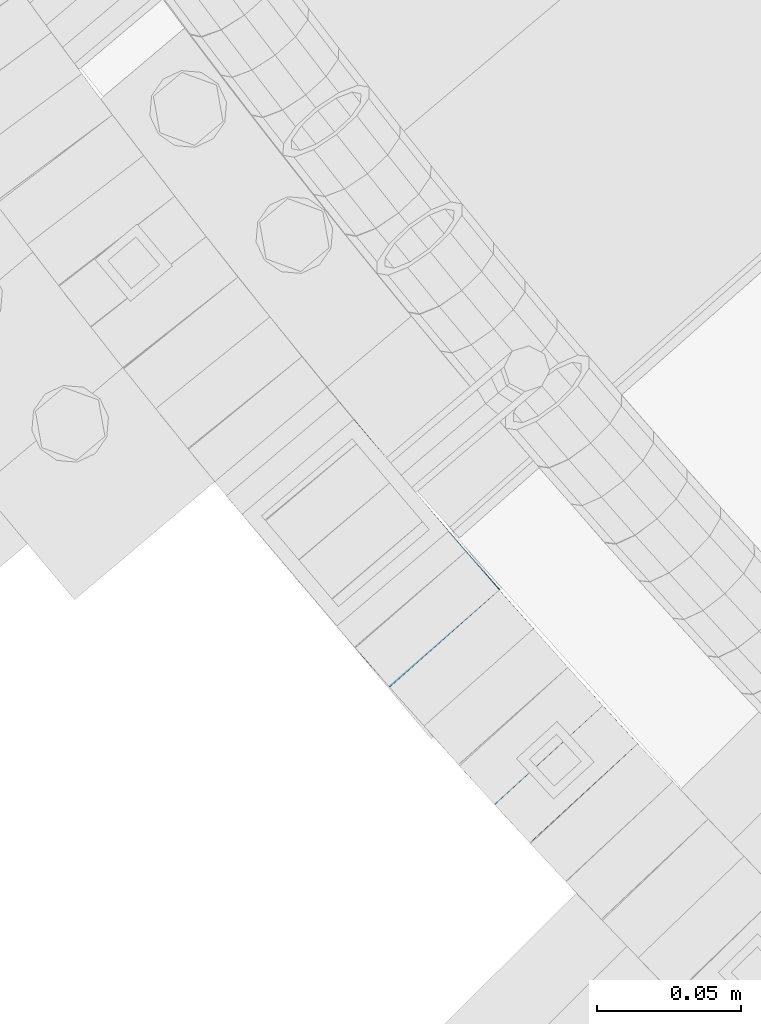
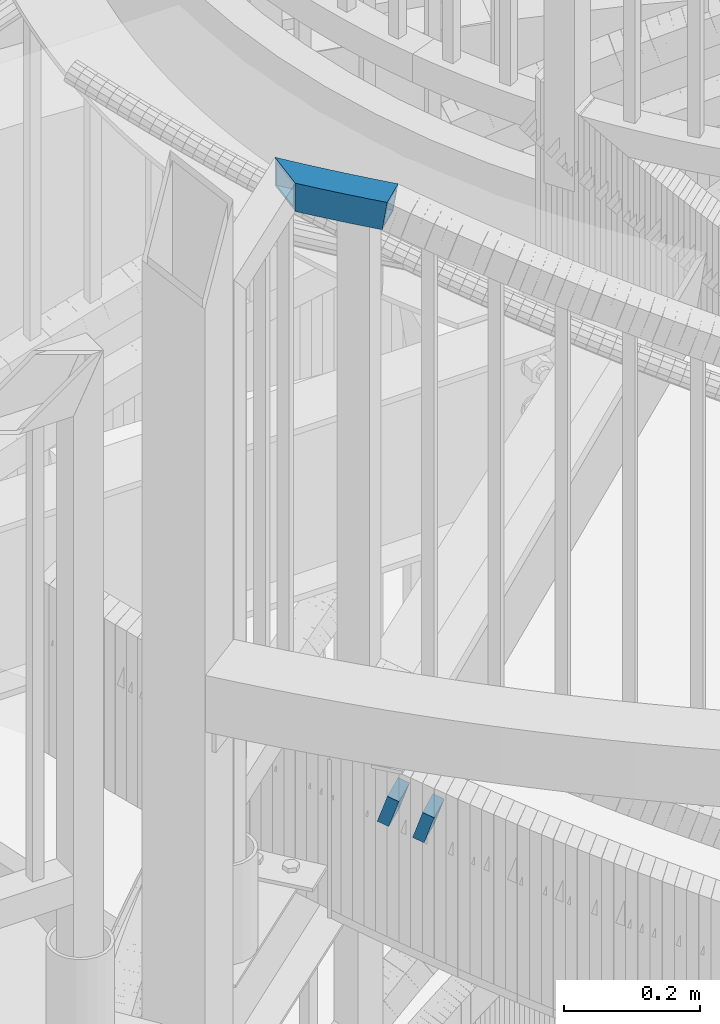
# One storey, part 464 of 975: 3 beams.
"""IFC2X3 building model written with IfcOpenShell, lengths in millimetres."""

import ifcopenshell
import ifcopenshell.guid

model = None  # the IFC model being written
_history = None  # IfcOwnerHistory: only IFC2X3 demands one
_inside = {}  # id of a spatial element -> (the spatial element, [elements in it])
_under = {}  # id of a project, library or spatial element -> (it, [spatial elements below it])
_declared = {}  # id of a project -> (the project, [libraries it declares])
_typed = {}  # id of a type object -> (the type object, [elements of that type])
_made_of = {}  # id of a material, layer set ... -> (it, [elements and type objects made of it])


def new_model(schema):
    """Start an empty IFC model of exactly this schema.

    Asked for "IFC4X3", IfcOpenShell would pick the latest addendum, in which some entities
    have other attributes; the version numbers below select the first issue.
    IFC2X3 requires an IfcOwnerHistory on every rooted entity: one is made here for all.
    """
    global model, _history
    if schema == "IFC4X3":
        model = ifcopenshell.file(schema_version=(4, 3, 0, 0))
    else:
        model = ifcopenshell.file(schema=schema)
    _inside.clear()
    _under.clear()
    _declared.clear()
    _typed.clear()
    _made_of.clear()
    _history = None
    if model.schema == "IFC2X3":
        org = make("IfcOrganization", Name="unknown")
        user = make(
            "IfcPersonAndOrganization",
            ThePerson=make("IfcPerson", FamilyName="unknown"),
            TheOrganization=org,
        )
        app = make(
            "IfcApplication",
            ApplicationDeveloper=org,
            Version="unknown",
            ApplicationFullName="unknown",
            ApplicationIdentifier="unknown",
        )
        _history = make(
            "IfcOwnerHistory",
            OwningUser=user,
            OwningApplication=app,
            ChangeAction="ADDED",
            CreationDate=0,
        )
    return model


def make(cls, **values):
    """One entity of the class cls with the attributes given. An attribute that is None is left unset."""
    return model.create_entity(
        cls, **{name: value for name, value in values.items() if value is not None}
    )


def rooted(cls, **values):
    """An entity with a GlobalId (a new one), such as an element, a storey or a relation."""
    return make(cls, GlobalId=ifcopenshell.guid.new(), OwnerHistory=_history, **values)


def si_unit(unit_type, name, prefix=None):
    """IfcSIUnit, for example si_unit("LENGTHUNIT", "METRE", prefix="MILLI")."""
    return make("IfcSIUnit", UnitType=unit_type, Prefix=prefix, Name=name)


def assignment(units):
    """IfcUnitAssignment: the units of a project."""
    return None if units is None else make("IfcUnitAssignment", Units=units)


def point(xyz):
    """IfcCartesianPoint."""
    return None if xyz is None else make("IfcCartesianPoint", Coordinates=xyz)


def direction(xyz):
    """IfcDirection."""
    return None if xyz is None else make("IfcDirection", DirectionRatios=xyz)


def frame(location, z_axis=None, x_axis=None):
    """IfcAxis2Placement3D, a coordinate frame: its origin and axes. An axis left out is left unset."""
    return make(
        "IfcAxis2Placement3D",
        Location=point(location),
        Axis=direction(z_axis),
        RefDirection=direction(x_axis),
    )


def origin_with_axes():
    """The frame at (0, 0, 0) with the z axis (0, 0, 1) and the x axis (1, 0, 0) written out."""
    return frame((0.0, 0.0, 0.0), z_axis=(0.0, 0.0, 1.0), x_axis=(1.0, 0.0, 0.0))


def place(relative_to, where):
    """IfcLocalPlacement: puts the frame where relative to a parent placement (None: the world)."""
    return make(
        "IfcLocalPlacement", PlacementRelTo=relative_to, RelativePlacement=where
    )


def context(
    kind, dimensions, precision=None, world=None, true_north=None, identifier=None
):
    """IfcGeometricRepresentationContext, for example the 3D "Model" context."""
    return make(
        "IfcGeometricRepresentationContext",
        ContextIdentifier=identifier,
        ContextType=kind,
        CoordinateSpaceDimension=dimensions,
        Precision=precision,
        WorldCoordinateSystem=world,
        TrueNorth=true_north,
    )


def subcontext(parent, identifier, kind, view, scale=None):
    """IfcGeometricRepresentationSubContext, for example "Body" below "Model"."""
    return make(
        "IfcGeometricRepresentationSubContext",
        ContextIdentifier=identifier,
        ContextType=kind,
        ParentContext=parent,
        TargetScale=scale,
        TargetView=view,
    )


def project(units=None, contexts=None):
    """IfcProject with its units and contexts."""
    return rooted(
        "IfcProject",
        Name="project",
        RepresentationContexts=contexts,
        UnitsInContext=assignment(units),
    )


def spatial(cls, under=None, at=None, **own):
    """A site, building, storey or space (cls), placed at a placement, below another one or the project."""
    s = rooted(cls, ObjectPlacement=at, **own)
    if under is not None:
        _under.setdefault(under.id(), (under, []))[1].append(s)
    return s


def faces_of(points, faces, orient=None, outer=None):
    """IfcFace entities. A face is a list of loops; a loop is a list of indices into points, from 0.

    orient and outer hold one flag for each loop. By default every Orientation is true, the
    first loop of a face is its IfcFaceOuterBound and the others are IfcFaceBound.
    """
    made = []
    for i, loops in enumerate(faces):
        bounds = []
        for j, loop in enumerate(loops):
            is_outer = j == 0 if outer is None else outer[i][j]
            bounds.append(
                make(
                    "IfcFaceOuterBound" if is_outer else "IfcFaceBound",
                    Bound=make("IfcPolyLoop", Polygon=[points[k] for k in loop]),
                    Orientation=True if orient is None else orient[i][j],
                )
            )
        made.append(make("IfcFace", Bounds=bounds))
    return made


def faceted_brep(points, faces, orient=None, outer=None, voids=None):
    """IfcFacetedBrep: a solid bounded by flat faces; with voids (closed shells), ...WithVoids."""
    shared = [point(p) for p in points]
    hull = make("IfcClosedShell", CfsFaces=faces_of(shared, faces, orient, outer))
    if voids is None:
        return make("IfcFacetedBrep", Outer=hull)
    return make(
        "IfcFacetedBrepWithVoids",
        Outer=hull,
        Voids=[
            make(cls, CfsFaces=faces_of(shared, fs, o, b)) for cls, fs, o, b in voids
        ],
    )


def shape(context_of_items, identifier, shape_type, items):
    """IfcShapeRepresentation: the items that make up one representation, for example the "Body"."""
    return make(
        "IfcShapeRepresentation",
        ContextOfItems=context_of_items,
        RepresentationIdentifier=identifier,
        RepresentationType=shape_type,
        Items=items,
    )


def material(Name=None, Category=None):
    """IfcMaterial."""
    return make("IfcMaterial", Name=Name, Category=Category)


def made_of(thing, what):
    """Note that an element or type object is made of a material, layer set ...; save() writes the relation."""
    if what is not None:
        _made_of.setdefault(what.id(), (what, []))[1].append(thing)
    return thing


def type_object(cls, material=None, **own):
    """A type object (cls), such as IfcWallType, which elements share."""
    return made_of(rooted(cls, **own), material)


def element(
    cls,
    number,
    at=None,
    inside=None,
    cuts=None,
    type_object=None,
    material=None,
    context=None,
    identifier="Body",
    shape_type=None,
    held_by="IfcProductDefinitionShape",
    body=None,
    shapes=None,
    **own,
):
    """One element of the class cls, such as IfcWall. Its Tag is "e" and its number.

    at: its placement. inside: the storey or other place that contains it. cuts: it is an
    opening in that element (IfcRelVoidsElement). A single representation is given by context,
    identifier, shape_type and body (its items); several are given by shapes. held_by: the class
    of the entity that holds the representations. save() writes the other relations.
    """
    e = rooted(cls, Tag="e%d" % number, ObjectPlacement=at, **own)
    if body is not None:
        shapes = [shape(context, identifier, shape_type, body)]
    if shapes is not None:
        e.Representation = make(held_by, Representations=shapes)
    if inside is not None:
        _inside.setdefault(inside.id(), (inside, []))[1].append(e)
    if cuts is not None:
        rooted(
            "IfcRelVoidsElement", RelatingBuildingElement=cuts, RelatedOpeningElement=e
        )
    if type_object is not None:
        _typed.setdefault(type_object.id(), (type_object, []))[1].append(e)
    return made_of(e, material)


def aggregate(whole, parts):
    """IfcRelAggregates: a whole, such as a stair, and the parts it consists of."""
    return rooted("IfcRelAggregates", RelatingObject=whole, RelatedObjects=parts)


def save(model, path):
    """Write the relations noted so far, then the file.

    IfcRelAggregates (storeys below a building ...), IfcRelContainedInSpatialStructure (elements
    in a storey), IfcRelDefinesByType, IfcRelAssociatesMaterial and IfcRelDeclares: one each for
    every whole, place, type object, material and project.
    """
    for whole, parts in _under.values():
        aggregate(whole, parts)
    for where, things in _inside.values():
        rooted(
            "IfcRelContainedInSpatialStructure",
            RelatedElements=things,
            RelatingStructure=where,
        )
    for kind, things in _typed.values():
        rooted("IfcRelDefinesByType", RelatedObjects=things, RelatingType=kind)
    for what, things in _made_of.values():
        rooted("IfcRelAssociatesMaterial", RelatedObjects=things, RelatingMaterial=what)
    for by, libraries in _declared.values():
        rooted("IfcRelDeclares", RelatingContext=by, RelatedDefinitions=libraries)
    model.write(path)


model = new_model("IFC2X3")

# Units and contexts
model_context = context("Model", 3, precision=1e-05, world=origin_with_axes())
body_context = subcontext(model_context, "Body", "Model", "MODEL_VIEW")
ifc_project = project(units=[si_unit("LENGTHUNIT", "METRE", prefix="MILLI"), si_unit("AREAUNIT", "SQUARE_METRE"), si_unit("VOLUMEUNIT", "CUBIC_METRE"), si_unit("MASSUNIT", "GRAM", prefix="KILO"), si_unit("TIMEUNIT", "SECOND"), si_unit("PLANEANGLEUNIT", "RADIAN"), si_unit("SOLIDANGLEUNIT", "STERADIAN"), si_unit("THERMODYNAMICTEMPERATUREUNIT", "DEGREE_CELSIUS"), si_unit("LUMINOUSINTENSITYUNIT", "LUMEN")], contexts=[model_context])

# Site, building, storey
site_placement = place(None, origin_with_axes())
site = spatial("IfcSite", under=ifc_project, at=site_placement, CompositionType="ELEMENT")
building_placement = place(site_placement, origin_with_axes())
building = spatial("IfcBuilding", under=site, at=building_placement, Name="Undefined", CompositionType="ELEMENT")
storey_placement = place(building_placement, origin_with_axes())
storey = spatial("IfcBuildingStorey", under=building, at=storey_placement, Name="Undefined", CompositionType="ELEMENT", Elevation=0.0)

# Beams
ifc_material = material()
beam_type = type_object("IfcBeamType", Name="HSS2X2X.188_TUBES", PredefinedType="NOTDEFINED")
beam_1_placement = place(storey_placement, frame((32612.3422775604, 1471.11594026846, 5130.8), z_axis=(0.0, 0.0, 1.0), x_axis=(-0.644936637664488, 0.76423604560242, 0.0)))
element("IfcBeam", 1, at=beam_1_placement, inside=storey, type_object=beam_type, material=ifc_material, Name="HANDRAIL", ObjectType="HSS2X2X.188_TUBES", context=body_context, shape_type="Brep", body=[
    faceted_brep([(55.4866860684269, -23.8479305757173, 25.3999999999996), (51.8505932737062, -23.9176642509301, 25.3999999999996), (51.8505932737062, -23.9176642509301, 0.0465926285069145), (55.4866860684269, -23.8479305757173, -23.6106126499226), (48.2145925969344, -23.9920462097361, 25.3999999999996), (48.2145925969344, -23.9920462097361, 23.703839084139), (47.9539081902258, -23.9977124561519, 25.3999999999996), (47.1431262087099, 26.7966529247497, 25.3999999999996), (47.1431262087099, 26.7966529247497, 23.6763622849121), (46.8782188694749, 26.7908948885088, 25.3999999999996), (50.8440554689951, 26.8723631328212, 25.3999999999996), (50.8440554689951, 26.8723631328212, -0.403335000283732), (184.092952909432, 26.4465017965631, -25.3999999999996), (184.092952909432, 26.4465017965631, 25.3999999999996), (187.793322633312, 26.3471371558007, 25.3999999999996), (187.793322633312, 26.3471371558007, -25.3999999999996), (180.392459182614, 26.5411358446399, -25.3999999999996), (180.392459182614, 26.5411358446399, 25.3999999999996), (176.691847500504, 26.6310391453771, -25.3999999999996), (176.691847500504, 26.6310391453771, 25.3999999999996), (172.991123910928, 26.7162115518404, -25.3999999999996), (172.991123910928, 26.7162115518404, 25.3999999999996), (169.290294461902, 26.7966529248406, -25.3999999999996), (169.290294461902, 26.7966529248406, 25.3999999999996), (165.589365201617, 26.8723631329085, -25.3999999999996), (165.589365201617, 26.8723631329085, 25.3999999999996), (161.888342178416, 26.9433420523128, -25.3999999999996), (161.888342178416, 26.9433420523128, 25.3999999999996), (158.187231440806, 27.0095895670602, -25.3999999999996), (158.187231440806, 27.0095895670602, 25.3999999999996), (154.486039037434, 27.0711055688807, -25.3999999999996), (154.486039037434, 27.0711055688807, 25.3999999999996), (150.784771017079, 27.1278899572353, -25.3999999999996), (150.784771017079, 27.1278899572353, 25.3999999999996), (147.083433428645, 27.1799426393336, -25.3999999999996), (147.083433428645, 27.1799426393336, 25.3999999999996), (143.382032321151, 27.2272635300942, -25.3999999999996), (143.382032321151, 27.2272635300942, 25.3999999999996), (139.680573743721, 27.2698525521919, -25.3999999999996), (139.680573743721, 27.2698525521919, 25.3999999999996), (135.979063745563, 27.3077096360139, -25.3999999999996), (135.979063745563, 27.3077096360139, 25.3999999999996), (132.277508375977, 27.3408347197001, -25.3999999999996), (132.277508375977, 27.3408347197001, 25.3999999999996), (128.575913684344, 27.3692277491136, -25.3999999999996), (128.575913684344, 27.3692277491136, 25.3999999999996), (124.874285720092, 27.3928886778449, -25.3999999999996), (124.874285720092, 27.3928886778449, 25.3999999999996), (121.172630532721, 27.4118174672403, -25.3999999999996), (121.172630532721, 27.4118174672403, 25.3999999999996), (117.470954171764, 27.4260140863444, -25.3999999999996), (117.470954171764, 27.4260140863444, 25.3999999999996), (113.769262686794, 27.4354785119758, -25.3999999999996), (113.769262686794, 27.4354785119758, 25.3999999999996), (110.067562127402, 27.4402107286551, -25.3999999999996), (110.067562127402, 27.4402107286551, 25.3999999999996), (106.365858543206, 27.4402107286514, -25.3999999999996), (106.365858543206, 27.4402107286514, 25.3999999999996), (102.664157983814, 27.4354785119649, -25.3999999999996), (102.664157983814, 27.4354785119649, 25.3999999999996), (98.9624664988478, 27.4260140863335, -25.3999999999996), (98.9624664988478, 27.4260140863335, 25.3999999999996), (95.2607901378906, 27.4118174672185, -25.3999999999996), (95.2607901378906, 27.4118174672185, 25.3999999999996), (91.5591349505194, 27.3928886778231, -25.3999999999996), (91.5591349505194, 27.3928886778231, 25.3999999999996), (87.8575069862709, 27.3692277490809, -25.3999999999996), (87.8575069862709, 27.3692277490809, 25.3999999999996), (84.1559122946346, 27.3408347196637, -25.3999999999996), (84.1559122946346, 27.3408347196637, 25.3999999999996), (80.4543569250491, 27.3077096359739, -25.3999999999996), (80.4543569250491, 27.3077096359739, 25.3999999999996), (76.7528469268946, 27.2698525521446, -25.3999999999996), (76.7528469268946, 27.2698525521446, 25.3999999999996), (73.0513883494568, 27.2272635300433, -25.3999999999996), (73.0513883494568, 27.2272635300433, 25.3999999999996), (69.3499872419634, 27.1799426392754, -25.3999999999996), (69.3499872419634, 27.1799426392754, 25.3999999999996), (65.6486496535326, 27.1278899571771, -25.3999999999996), (65.6486496535326, 27.1278899571771, 25.3999999999996), (61.9473816331774, 27.0711055688153, -25.3999999999996), (61.9473816331774, 27.0711055688153, 25.3999999999996), (58.2461892298052, 27.0095895669911, -25.3999999999996), (58.2461892298052, 27.0095895669911, 25.3999999999996), (54.5450784921959, 26.9433420522364, -25.3999999999996), (54.5450784921959, 26.9433420522364, 25.3999999999996), (233.854294109802, -21.3677338411799, -20.6374999999998), (233.854294109802, -21.3677338411799, 20.6374999999998), (237.493497984808, -21.5306737560713, 20.6374999999998), (237.493497984808, -21.5306737560713, -20.6374999999998), (230.214884907968, -21.2094463771828, -20.6374999999998), (230.214884907968, -21.2094463771828, 20.6374999999998), (226.575276327105, -21.0558116227694, -20.6374999999998), (226.575276327105, -21.0558116227694, 20.6374999999998), (222.935474315345, -20.9068298290149, -20.6374999999998), (222.935474315345, -20.9068298290149, 20.6374999999998), (219.295484821145, -20.7625012394019, -20.6374999999998), (219.295484821145, -20.7625012394019, 20.6374999999998), (215.655313793257, -20.6228260897988, -20.6374999999998), (215.655313793257, -20.6228260897988, 20.6374999999998), (212.014967180745, -20.4878046084814, -20.6374999999998), (212.014967180745, -20.4878046084814, 20.6374999999998), (208.374450932941, -20.3574370161041, -20.6374999999998), (208.374450932941, -20.3574370161041, 20.6374999999998), (204.733770999461, -20.2317235257287, -20.6374999999998), (204.733770999461, -20.2317235257287, 20.6374999999998), (201.092933330205, -20.1106643428066, -20.6374999999998), (201.092933330205, -20.1106643428066, 20.6374999999998), (197.451943875305, -19.9942596651781, -20.6374999999998), (197.451943875305, -19.9942596651781, 20.6374999999998), (193.810808585153, -19.8825096830842, -20.6374999999998), (193.810808585153, -19.8825096830842, 20.6374999999998), (190.169533410386, -19.775414579155, -20.6374999999998), (190.169533410386, -19.775414579155, 20.6374999999998), (186.528124301854, -19.6729745284174, -20.6374999999998), (186.528124301854, -19.6729745284174, 20.6374999999998), (182.886587210643, -19.5751896982802, -20.6374999999998), (182.886587210643, -19.5751896982802, 20.6374999999998), (179.244928088039, -19.4820602485524, -20.6374999999998), (179.244928088039, -19.4820602485524, 20.6374999999998), (175.60315288552, -19.3935863314364, -20.6374999999998), (175.60315288552, -19.3935863314364, 20.6374999999998), (171.961267554772, -19.3097680915198, -20.6374999999998), (171.961267554772, -19.3097680915198, 20.6374999999998), (168.319278047649, -19.2306056657908, -20.6374999999998), (168.319278047649, -19.2306056657908, 20.6374999999998), (164.677190316168, -19.1560991836195, -20.6374999999998), (164.677190316168, -19.1560991836195, 20.6374999999998), (161.035010312524, -19.0862487667655, -20.6374999999998), (161.035010312524, -19.0862487667655, 20.6374999999998), (157.392743989058, -19.0210545293921, -20.6374999999998), (157.392743989058, -19.0210545293921, 20.6374999999998), (153.750397298238, -18.9605165780449, -20.6374999999998), (153.750397298238, -18.9605165780449, 20.6374999999998), (150.107976192678, -18.9046350116514, -20.6374999999998), (150.107976192678, -18.9046350116514, 20.6374999999998), (146.465486625115, -18.8534099215394, -20.6374999999998), (146.465486625115, -18.8534099215394, 20.6374999999998), (142.822934548385, -18.8068413914334, -20.6374999999998), (142.822934548385, -18.8068413914334, 20.6374999999998), (139.18032591544, -18.764929497429, -20.6374999999998), (139.18032591544, -18.764929497429, 20.6374999999998), (135.537666679313, -18.7276743080256, -20.6374999999998), (135.537666679313, -18.7276743080256, 20.6374999999998), (131.894962793129, -18.6950758841158, -20.6374999999998), (131.894962793129, -18.6950758841158, 20.6374999999998), (128.252220210077, -18.6671342789668, -20.6374999999998), (128.252220210077, -18.6671342789668, 20.6374999999998), (124.609444883419, -18.6438495382426, -20.6374999999998), (124.609444883419, -18.6438495382426, 20.6374999999998), (120.96664276646, -18.6252217000001, -20.6374999999998), (120.96664276646, -18.6252217000001, 20.6374999999998), (117.323819812558, -18.6112507946818, -20.6374999999998), (117.323819812558, -18.6112507946818, 20.6374999999998), (113.680981975103, -18.6019368451161, -20.6374999999998), (113.680981975103, -18.6019368451161, 20.6374999999998), (110.038135207498, -18.5972798665316, -20.6374999999998), (110.038135207498, -18.5972798665316, 20.6374999999998), (106.395285463183, -18.5972798665352, -20.6374999999998), (106.395285463183, -18.5972798665352, 20.6374999999998), (102.752438695577, -18.6019368451271, -20.6374999999998), (102.752438695577, -18.6019368451271, 20.6374999999998), (99.1096008581226, -18.6112507946964, -20.6374999999998), (99.1096008581226, -18.6112507946964, 20.6374999999998), (95.4667779042175, -18.6252217000183, -20.6374999999998), (95.4667779042175, -18.6252217000183, 20.6374999999998), (91.8239757872652, -18.6438495382645, -20.6374999999998), (91.8239757872652, -18.6438495382645, 20.6374999999998), (88.1812004606036, -18.6671342789996, -20.6374999999998), (88.1812004606036, -18.6671342789996, 20.6374999999998), (84.538457877552, -18.6950758841485, -20.6374999999998), (84.538457877552, -18.6950758841485, 20.6374999999998), (80.8957539913681, -18.7276743080693, -20.6374999999998), (80.8957539913681, -18.7276743080693, 20.6374999999998), (77.2530947552405, -18.7649294974726, -20.6374999999998), (77.2530947552405, -18.7649294974726, 20.6374999999998), (73.6104861222957, -18.8068413914807, -20.6374999999998), (73.6104861222957, -18.8068413914807, 20.6374999999998), (69.9679340455659, -18.8534099215976, -20.6374999999998), (69.9679340455659, -18.8534099215976, 20.6374999999998), (66.3254444780032, -18.9046350117096, -20.6374999999998), (66.3254444780032, -18.9046350117096, 20.6374999999998), (62.6830233724468, -18.9605165781068, -20.6374999999998), (62.6830233724468, -18.9605165781068, 20.6374999999998), (59.0406766816268, -19.0210545294649, -20.6374999999998), (59.0406766816268, -19.0210545294649, 20.6374999999998), (55.398410358157, -19.0862487668492, -20.6374999999998), (55.398410358157, -19.0862487668492, 20.6374999999998), (51.7562303545164, -19.1560991837032, 20.6374999999998), (54.9288750643973, -19.0952536035002, -20.6374999999998), (51.7562303545164, -19.1560991837032, 0.00441191330810398), (48.5850277216196, -19.2209727314766, 20.6374999999998), (50.9384183881848, 22.1107980655943, 20.6374999999998), (47.7110300556051, 22.0447751224347, 20.6374999999998), (50.9384183881848, 22.1107980655943, -0.361154285084922), (54.6333542024695, 22.1816602433646, -20.6374999999998), (54.6333542024695, 22.1816602433646, 20.6374999999998), (54.0548758771256, 22.1705660766493, -20.6374999999998), (58.3283775868877, 22.2477987983875, -20.6374999999998), (58.3283775868877, 22.2477987983875, 20.6374999999998), (62.0234825027546, 22.3092136225787, -20.6374999999998), (62.0234825027546, 22.3092136225787, 20.6374999999998), (65.7186629112366, 22.3659046155663, -20.6374999999998), (65.7186629112366, 22.3659046155663, 20.6374999999998), (69.4139127733724, 22.4178716847018, -20.6374999999998), (69.4139127733724, 22.4178716847018, 20.6374999999998), (73.1092260500955, 22.4651147450604, -20.6374999999998), (73.1092260500955, 22.4651147450604, 20.6374999999998), (76.8045967022372, 22.5076337194223, -20.6374999999998), (76.8045967022372, 22.5076337194223, 20.6374999999998), (80.5000186905309, 22.545428538313, -20.6374999999998), (80.5000186905309, 22.545428538313, 20.6374999999998), (84.1954859756261, 22.5784991399596, -20.6374999999998), (84.1954859756261, 22.5784991399596, 20.6374999999998), (87.890992518096, 22.6068454703163, -20.6374999999998), (87.890992518096, 22.6068454703163, 20.6374999999998), (91.5865322784557, 22.6304674830535, -20.6374999999998), (91.5865322784557, 22.6304674830535, 20.6374999999998), (95.2820992171655, 22.6493651395758, -20.6374999999998), (95.2820992171655, 22.6493651395758, 20.6374999999998), (98.9776872946313, 22.6635384089859, -20.6374999999998), (98.9776872946313, 22.6635384089859, 20.6374999999998), (102.673290471241, 22.6729872681317, -20.6374999999998), (102.673290471241, 22.6729872681317, 20.6374999999998), (106.368902707341, 22.6777117015663, -20.6374999999998), (106.368902707341, 22.6777117015663, 20.6374999999998), (110.064517963274, 22.6777117015663, -20.6374999999998), (110.064517963274, 22.6777117015663, 20.6374999999998), (113.760130199378, 22.672987268139, -20.6374999999998), (113.760130199378, 22.672987268139, 20.6374999999998), (117.455733375988, 22.6635384090005, -20.6374999999998), (117.455733375988, 22.6635384090005, 20.6374999999998), (121.151321453453, 22.6493651395904, -20.6374999999998), (121.151321453453, 22.6493651395904, 20.6374999999998), (124.846888392163, 22.630467483079, -20.6374999999998), (124.846888392163, 22.630467483079, 20.6374999999998), (128.542428152523, 22.6068454703454, -20.6374999999998), (128.542428152523, 22.6068454703454, 20.6374999999998), (132.237934694993, 22.5784991399996, -20.6374999999998), (132.237934694993, 22.5784991399996, 20.6374999999998), (135.933401980088, 22.545428538353, -20.6374999999998), (135.933401980088, 22.545428538353, 20.6374999999998), (139.628823968378, 22.5076337194732, -20.6374999999998), (139.628823968378, 22.5076337194732, 20.6374999999998), (143.324194620523, 22.4651147451114, -20.6374999999998), (143.324194620523, 22.4651147451114, 20.6374999999998), (147.01950789725, 22.41787168476, -20.6374999999998), (147.01950789725, 22.41787168476, 20.6374999999998), (150.714757759382, 22.3659046156281, -20.6374999999998), (150.714757759382, 22.3659046156281, 20.6374999999998), (154.409938167861, 22.3092136226478, -20.6374999999998), (154.409938167861, 22.3092136226478, 20.6374999999998), (158.105043083731, 22.2477987984603, -20.6374999999998), (158.105043083731, 22.2477987984603, 20.6374999999998), (161.800066468149, 22.1816602434446, -20.6374999999998), (161.800066468149, 22.1816602434446, 20.6374999999998), (165.495002282434, 22.110798065678, -20.6374999999998), (165.495002282434, 22.110798065678, 20.6374999999998), (169.189844488013, 22.0352123809826, -20.6374999999998), (169.189844488013, 22.0352123809826, 20.6374999999998), (172.884587046497, 21.9549033128751, -20.6374999999998), (172.884587046497, 21.9549033128751, 20.6374999999998), (176.579223919645, 21.869870992603, -20.6374999999998), (176.579223919645, 21.869870992603, 20.6374999999998), (180.273749069383, 21.7801155591369, -20.6374999999998), (180.273749069383, 21.7801155591369, 20.6374999999998), (183.968156457831, 21.6856371591675, -20.6374999999998), (183.968156457831, 21.6856371591675, 20.6374999999998), (187.662440047297, 21.586435947087, -20.6374999999998), (187.662440047297, 21.586435947087, 20.6374999999998), (191.356593800301, 21.4825120850292, -20.6374999999998), (191.356593800301, 21.4825120850292, 20.6374999999998), (195.050611679551, 21.3738657428257, -20.6374999999998), (195.050611679551, 21.3738657428257, 20.6374999999998), (195.799323266823, 21.3508870562873, -20.6374999999998), (195.799323266823, 21.3508870562873, 20.6374999999998), (55.761720863713, -23.8430076288096, -25.3999999999996), (59.1228650387129, -23.7828452980684, -25.3999999999996), (59.1228650387129, -23.7828452980684, 25.3999999999996), (62.759124242024, -23.7224085243433, -25.3999999999996), (62.759124242024, -23.7224085243433, 25.3999999999996), (66.3954577357072, -23.6666203533205, -25.3999999999996), (66.3954577357072, -23.6666203533205, 25.3999999999996), (70.031859576975, -23.6154808761712, -25.3999999999996), (70.031859576975, -23.6154808761712, 25.3999999999996), (73.6683238229343, -23.5689901764672, -25.3999999999996), (73.6683238229343, -23.5689901764672, 25.3999999999996), (77.3048445305867, -23.5271483301949, -25.3999999999996), (77.3048445305867, -23.5271483301949, 25.3999999999996), (80.9414157568463, -23.4899554057265, -25.3999999999996), (80.9414157568463, -23.4899554057265, 25.3999999999996), (84.5780315585471, -23.4574114638563, -25.3999999999996), (84.5780315585471, -23.4574114638563, 25.3999999999996), (88.2146859924287, -23.4295165577641, -25.3999999999996), (88.2146859924287, -23.4295165577641, 25.3999999999996), (91.8513731152016, -23.406270733034, -25.3999999999996), (91.8513731152016, -23.406270733034, 25.3999999999996), (95.488086983496, -23.3876740276646, -25.3999999999996), (95.488086983496, -23.3876740276646, 25.3999999999996), (99.1248216539097, -23.3737264720403, -25.3999999999996), (99.1248216539097, -23.3737264720403, 25.3999999999996), (102.761571183008, -23.3644280889639, -25.3999999999996), (102.761571183008, -23.3644280889639, 25.3999999999996), (106.398329627318, -23.359778893624, -25.3999999999996), (106.398329627318, -23.359778893624, 25.3999999999996), (110.035091043374, -23.3597788936204, -25.3999999999996), (110.035091043374, -23.3597788936204, 25.3999999999996), (113.671849487684, -23.364428088953, -25.3999999999996), (113.671849487684, -23.364428088953, 25.3999999999996), (117.308599016782, -23.3737264720257, -25.3999999999996), (117.308599016782, -23.3737264720257, 25.3999999999996), (120.945333687192, -23.3876740276464, -25.3999999999996), (120.945333687192, -23.3876740276464, 25.3999999999996), (124.582047555483, -23.4062707330122, -25.3999999999996), (124.582047555483, -23.4062707330122, 25.3999999999996), (128.218734678256, -23.4295165577314, -25.3999999999996), (128.218734678256, -23.4295165577314, 25.3999999999996), (131.855389112145, -23.4574114638199, -25.3999999999996), (131.855389112145, -23.4574114638199, 25.3999999999996), (135.492004913838, -23.4899554056901, -25.3999999999996), (135.492004913838, -23.4899554056901, 25.3999999999996), (139.128576140101, -23.5271483301476, -25.3999999999996), (139.128576140101, -23.5271483301476, 25.3999999999996), (142.765096847754, -23.5689901764199, -25.3999999999996), (142.765096847754, -23.5689901764199, 25.3999999999996), (146.401561093713, -23.615480876113, -25.3999999999996), (146.401561093713, -23.615480876113, 25.3999999999996), (150.037962934981, -23.6666203532586, -25.3999999999996), (150.037962934981, -23.6666203532586, 25.3999999999996), (153.674296428664, -23.7224085242742, -25.3999999999996), (153.674296428664, -23.7224085242742, 25.3999999999996), (157.310555631975, -23.782845297992, -25.3999999999996), (157.310555631975, -23.782845297992, 25.3999999999996), (160.946734602261, -23.8479305756409, -25.3999999999996), (160.946734602261, -23.8479305756409, 25.3999999999996), (164.582827396982, -23.9176642508501, -25.3999999999996), (164.582827396982, -23.9176642508501, 25.3999999999996), (168.218828073757, -23.9920462096488, -25.3999999999996), (168.218828073757, -23.9920462096488, 25.3999999999996), (171.854730690346, -24.0710763304887, -25.3999999999996), (171.854730690346, -24.0710763304887, 25.3999999999996), (175.490529304665, -24.1547544842069, -25.3999999999996), (175.490529304665, -24.1547544842069, 25.3999999999996), (179.126217974805, -24.2430805340555, -25.3999999999996), (179.126217974805, -24.2430805340555, 25.3999999999996), (182.76179075905, -24.3360543356757, -25.3999999999996), (182.76179075905, -24.3360543356757, 25.3999999999996), (186.397241715844, -24.4336757371275, -25.3999999999996), (186.397241715844, -24.4336757371275, 25.3999999999996), (190.032564903857, -24.5359445788708, -25.3999999999996), (190.032564903857, -24.5359445788708, 25.3999999999996), (193.667754381953, -24.6428606937698, -25.3999999999996), (193.667754381953, -24.6428606937698, 25.3999999999996), (197.302804209223, -24.7544239070885, -25.3999999999996), (197.302804209223, -24.7544239070885, 25.3999999999996), (200.937708444981, -24.8706340365061, -25.3999999999996), (200.937708444981, -24.8706340365061, 25.3999999999996), (204.572461148775, -24.9914908921055, -25.3999999999996), (204.572461148775, -24.9914908921055, 25.3999999999996), (208.207056380408, -25.11699427637, -25.3999999999996), (208.207056380408, -25.11699427637, 25.3999999999996), (211.841488199945, -25.2471439841902, -25.3999999999996), (211.841488199945, -25.2471439841902, 25.3999999999996), (215.475750667705, -25.3819398028681, -25.3999999999996), (215.475750667705, -25.3819398028681, 25.3999999999996), (219.109837844291, -25.521381512106, -25.3999999999996), (219.109837844291, -25.521381512106, 25.3999999999996), (222.74374379059, -25.6654688840244, -25.3999999999996), (222.74374379059, -25.6654688840244, 25.3999999999996), (226.377462567787, -25.8142016831371, -25.3999999999996), (226.377462567787, -25.8142016831371, 25.3999999999996), (230.010988237373, -25.967579666376, -25.3999999999996), (230.010988237373, -25.967579666376, 25.3999999999996), (233.644314861158, -26.1256025830735, -25.3999999999996), (233.644314861158, -26.1256025830735, 25.3999999999996), (237.27743650127, -26.2882701749913, -25.3999999999996), (237.27743650127, -26.2882701749913, 25.3999999999996), (240.910347220175, -26.455582176266, -25.3999999999996), (240.910347220175, -26.455582176266, 25.3999999999996), (242.004047282044, -26.5073532434471, 25.3999999999996), (191.064541421507, 26.2551112920046, 25.3999999999996), (191.064541421507, 26.2551112920046, -25.3999999999996), (242.004047282044, -26.5073532434471, -25.3999999999996)], [[[0, 1, 2, 3]], [[1, 4, 5, 2]], [[4, 6, 5]], [[7, 8, 9]], [[7, 10, 11, 8]], [[12, 13, 14, 15]], [[16, 17, 13, 12]], [[18, 19, 17, 16]], [[20, 21, 19, 18]], [[22, 23, 21, 20]], [[24, 25, 23, 22]], [[26, 27, 25, 24]], [[28, 29, 27, 26]], [[30, 31, 29, 28]], [[32, 33, 31, 30]], [[34, 35, 33, 32]], [[36, 37, 35, 34]], [[38, 39, 37, 36]], [[40, 41, 39, 38]], [[42, 43, 41, 40]], [[44, 45, 43, 42]], [[46, 47, 45, 44]], [[48, 49, 47, 46]], [[50, 51, 49, 48]], [[52, 53, 51, 50]], [[54, 55, 53, 52]], [[56, 57, 55, 54]], [[58, 59, 57, 56]], [[60, 61, 59, 58]], [[62, 63, 61, 60]], [[64, 65, 63, 62]], [[66, 67, 65, 64]], [[68, 69, 67, 66]], [[70, 71, 69, 68]], [[72, 73, 71, 70]], [[74, 75, 73, 72]], [[76, 77, 75, 74]], [[78, 79, 77, 76]], [[80, 81, 79, 78]], [[82, 83, 81, 80]], [[84, 85, 83, 82]], [[10, 85, 84, 11]], [[86, 87, 88, 89]], [[90, 91, 87, 86]], [[92, 93, 91, 90]], [[94, 95, 93, 92]], [[96, 97, 95, 94]], [[98, 99, 97, 96]], [[100, 101, 99, 98]], [[102, 103, 101, 100]], [[104, 105, 103, 102]], [[106, 107, 105, 104]], [[108, 109, 107, 106]], [[110, 111, 109, 108]], [[112, 113, 111, 110]], [[114, 115, 113, 112]], [[116, 117, 115, 114]], [[118, 119, 117, 116]], [[120, 121, 119, 118]], [[122, 123, 121, 120]], [[124, 125, 123, 122]], [[126, 127, 125, 124]], [[128, 129, 127, 126]], [[130, 131, 129, 128]], [[132, 133, 131, 130]], [[134, 135, 133, 132]], [[136, 137, 135, 134]], [[138, 139, 137, 136]], [[140, 141, 139, 138]], [[142, 143, 141, 140]], [[144, 145, 143, 142]], [[146, 147, 145, 144]], [[148, 149, 147, 146]], [[150, 151, 149, 148]], [[152, 153, 151, 150]], [[154, 155, 153, 152]], [[156, 157, 155, 154]], [[158, 159, 157, 156]], [[160, 161, 159, 158]], [[162, 163, 161, 160]], [[164, 165, 163, 162]], [[166, 167, 165, 164]], [[168, 169, 167, 166]], [[170, 171, 169, 168]], [[172, 173, 171, 170]], [[174, 175, 173, 172]], [[176, 177, 175, 174]], [[178, 179, 177, 176]], [[180, 181, 179, 178]], [[182, 183, 181, 180]], [[184, 185, 183, 182]], [[186, 187, 185, 184]], [[188, 187, 186, 189, 190]], [[188, 190, 191]], [[192, 193, 194]], [[195, 196, 192, 194, 197]], [[196, 195, 198, 199]], [[199, 198, 200, 201]], [[201, 200, 202, 203]], [[203, 202, 204, 205]], [[205, 204, 206, 207]], [[207, 206, 208, 209]], [[209, 208, 210, 211]], [[211, 210, 212, 213]], [[213, 212, 214, 215]], [[215, 214, 216, 217]], [[217, 216, 218, 219]], [[219, 218, 220, 221]], [[221, 220, 222, 223]], [[223, 222, 224, 225]], [[225, 224, 226, 227]], [[227, 226, 228, 229]], [[229, 228, 230, 231]], [[231, 230, 232, 233]], [[233, 232, 234, 235]], [[235, 234, 236, 237]], [[237, 236, 238, 239]], [[239, 238, 240, 241]], [[241, 240, 242, 243]], [[243, 242, 244, 245]], [[245, 244, 246, 247]], [[247, 246, 248, 249]], [[249, 248, 250, 251]], [[251, 250, 252, 253]], [[253, 252, 254, 255]], [[255, 254, 256, 257]], [[257, 256, 258, 259]], [[259, 258, 260, 261]], [[261, 260, 262, 263]], [[263, 262, 264, 265]], [[265, 264, 266, 267]], [[267, 266, 268, 269]], [[269, 268, 270, 271]], [[271, 270, 272, 273]], [[273, 272, 274, 275]], [[87, 91, 93, 95, 97, 99, 101, 103, 105, 107, 109, 111, 113, 115, 117, 119, 121, 123, 125, 127, 129, 131, 133, 135, 137, 139, 141, 143, 145, 147, 149, 151, 153, 155, 157, 159, 161, 163, 165, 167, 169, 171, 173, 175, 177, 179, 181, 183, 185, 187, 188, 191, 193, 192, 196, 199, 201, 203, 205, 207, 209, 211, 213, 215, 217, 219, 221, 223, 225, 227, 229, 231, 233, 235, 237, 239, 241, 243, 245, 247, 249, 251, 253, 255, 257, 259, 261, 263, 265, 267, 269, 271, 273, 275, 88]], [[272, 270, 268, 266, 264, 262, 260, 258, 256, 254, 252, 250, 248, 246, 244, 242, 240, 238, 236, 234, 232, 230, 228, 226, 224, 222, 220, 218, 216, 214, 212, 210, 208, 206, 204, 202, 200, 198, 195, 197, 189, 186, 184, 182, 180, 178, 176, 174, 172, 170, 168, 166, 164, 162, 160, 158, 156, 154, 152, 150, 148, 146, 144, 142, 140, 138, 136, 134, 132, 130, 128, 126, 124, 122, 120, 118, 116, 114, 112, 110, 108, 106, 104, 102, 100, 98, 96, 94, 92, 90, 86, 89, 274]], [[2, 5, 6, 9, 8, 11, 84, 276, 3], [194, 193, 191, 190, 189, 197]], [[277, 278, 0, 3, 276]], [[278, 277, 279, 280]], [[280, 279, 281, 282]], [[282, 281, 283, 284]], [[284, 283, 285, 286]], [[286, 285, 287, 288]], [[288, 287, 289, 290]], [[290, 289, 291, 292]], [[292, 291, 293, 294]], [[294, 293, 295, 296]], [[296, 295, 297, 298]], [[298, 297, 299, 300]], [[300, 299, 301, 302]], [[302, 301, 303, 304]], [[304, 303, 305, 306]], [[306, 305, 307, 308]], [[308, 307, 309, 310]], [[310, 309, 311, 312]], [[312, 311, 313, 314]], [[314, 313, 315, 316]], [[316, 315, 317, 318]], [[318, 317, 319, 320]], [[320, 319, 321, 322]], [[322, 321, 323, 324]], [[324, 323, 325, 326]], [[326, 325, 327, 328]], [[328, 327, 329, 330]], [[330, 329, 331, 332]], [[332, 331, 333, 334]], [[334, 333, 335, 336]], [[336, 335, 337, 338]], [[338, 337, 339, 340]], [[340, 339, 341, 342]], [[342, 341, 343, 344]], [[344, 343, 345, 346]], [[346, 345, 347, 348]], [[348, 347, 349, 350]], [[350, 349, 351, 352]], [[352, 351, 353, 354]], [[354, 353, 355, 356]], [[356, 355, 357, 358]], [[358, 357, 359, 360]], [[360, 359, 361, 362]], [[362, 361, 363, 364]], [[364, 363, 365, 366]], [[366, 365, 367, 368]], [[368, 367, 369, 370]], [[370, 369, 371, 372]], [[372, 371, 373, 374]], [[374, 373, 375, 376]], [[376, 375, 377, 378]], [[14, 13, 17, 19, 21, 23, 25, 27, 29, 31, 33, 35, 37, 39, 41, 43, 45, 47, 49, 51, 53, 55, 57, 59, 61, 63, 65, 67, 69, 71, 73, 75, 77, 79, 81, 83, 85, 10, 7, 9, 6, 4, 1, 0, 278, 280, 282, 284, 286, 288, 290, 292, 294, 296, 298, 300, 302, 304, 306, 308, 310, 312, 314, 316, 318, 320, 322, 324, 326, 328, 330, 332, 334, 336, 338, 340, 342, 344, 346, 348, 350, 352, 354, 356, 358, 360, 362, 364, 366, 368, 370, 372, 374, 376, 378, 379, 380]], [[15, 14, 380, 381]], [[377, 375, 373, 371, 369, 367, 365, 363, 361, 359, 357, 355, 353, 351, 349, 347, 345, 343, 341, 339, 337, 335, 333, 331, 329, 327, 325, 323, 321, 319, 317, 315, 313, 311, 309, 307, 305, 303, 301, 299, 297, 295, 293, 291, 289, 287, 285, 283, 281, 279, 277, 276, 84, 82, 80, 78, 76, 74, 72, 70, 68, 66, 64, 62, 60, 58, 56, 54, 52, 50, 48, 46, 44, 42, 40, 38, 36, 34, 32, 30, 28, 26, 24, 22, 20, 18, 16, 12, 15, 381, 382]], [[378, 377, 382, 379]], [[381, 380, 379, 382], [274, 89, 88, 275]]]),
])
beam_2_placement = place(storey_placement, frame((32575.3799177036, 1512.05580274484, 4065.23408316391), z_axis=(0.747717099310188, 0.664017424017742, -6.23676896793769e-11), x_axis=(0.631755506003828, -0.711388553004306, -0.307914448001856)))
element("IfcBeam", 2, at=beam_2_placement, inside=storey, type_object=beam_type, material=ifc_material, Name="WALL", ObjectType="HSS2X2X.188_TUBES", context=body_context, shape_type="Brep", body=[
    faceted_brep([(0.0, 20.6374999999753, -20.6375000000298), (0.0, -20.6375000000153, -20.6375000000153), (18.8433011969464, -20.6374999999898, -20.6375000000226), (18.8433011969719, 20.6375000000007, -20.6374999999862), (0.0, -20.6374999999825, 20.6375000000335), (18.8433011969828, -20.6375000000044, 20.6375000000189), (0.0, 20.6375000000116, 20.6375000000189), (18.8433011970155, 20.6374999999862, 20.6375000000517), (0.0, 25.3999999999724, -25.4000000000342), (0.0, 25.400000000016, 25.4000000000196), (18.8433011970228, 25.3999999999833, 25.4000000000597), (18.8433011969719, 25.4000000000015, -25.3999999999869), (0.0, -25.399999999976, 25.4000000000378), (18.8433011969864, -25.4000000000051, 25.4000000000196), (0.0, -25.400000000016, -25.4000000000196), (18.8433011969391, -25.3999999999869, -25.4000000000269)], [[[0, 1, 2, 3]], [[1, 4, 5, 2]], [[4, 6, 7, 5]], [[6, 0, 3, 7]], [[8, 9, 10, 11]], [[9, 12, 13, 10]], [[12, 14, 15, 13]], [[14, 8, 11, 15]], [[13, 15, 11, 10], [5, 7, 3, 2]], [[14, 12, 9, 8], [6, 4, 1, 0]]]),
])
beam_3_placement = place(storey_placement, frame((32611.4527775659, 1471.58005594781, 4048.03594077775), z_axis=(0.737154140248182, 0.675724628465592, -1.81917584995972e-10), x_axis=(0.642844486019852, -0.701284894021641, -0.308140332009505)))
element("IfcBeam", 3, at=beam_3_placement, inside=storey, type_object=beam_type, material=ifc_material, Name="WALL", ObjectType="HSS2X2X.188_TUBES", context=body_context, shape_type="Brep", body=[
    faceted_brep([(0.0, 20.6374999999753, -20.6375000000298), (0.0, -20.6375000000153, -20.6375000000153), (18.8225928075335, -20.6374999999935, -20.6375000000298), (18.8225928075699, 20.6374999999898, -20.6374999999825), (0.0, -20.6374999999825, 20.6375000000335), (18.8225928075772, -20.637500000008, 20.6375000000226), (0.0, 20.6375000000116, 20.6375000000189), (18.8225928076135, 20.6374999999753, 20.6375000000698), (0.0, 25.3999999999724, -25.4000000000342), (0.0, 25.400000000016, 25.4000000000196), (18.8225928076281, 25.3999999999705, 25.4000000000815), (18.8225928075663, 25.3999999999905, -25.3999999999796), (0.0, -25.399999999976, 25.4000000000378), (18.8225928075808, -25.4000000000087, 25.4000000000233), (0.0, -25.400000000016, -25.4000000000196), (18.8225928075226, -25.3999999999905, -25.4000000000378)], [[[0, 1, 2, 3]], [[1, 4, 5, 2]], [[4, 6, 7, 5]], [[6, 0, 3, 7]], [[8, 9, 10, 11]], [[9, 12, 13, 10]], [[12, 14, 15, 13]], [[14, 8, 11, 15]], [[13, 15, 11, 10], [5, 7, 3, 2]], [[14, 12, 9, 8], [6, 4, 1, 0]]]),
])

save(model, "model.ifc")
